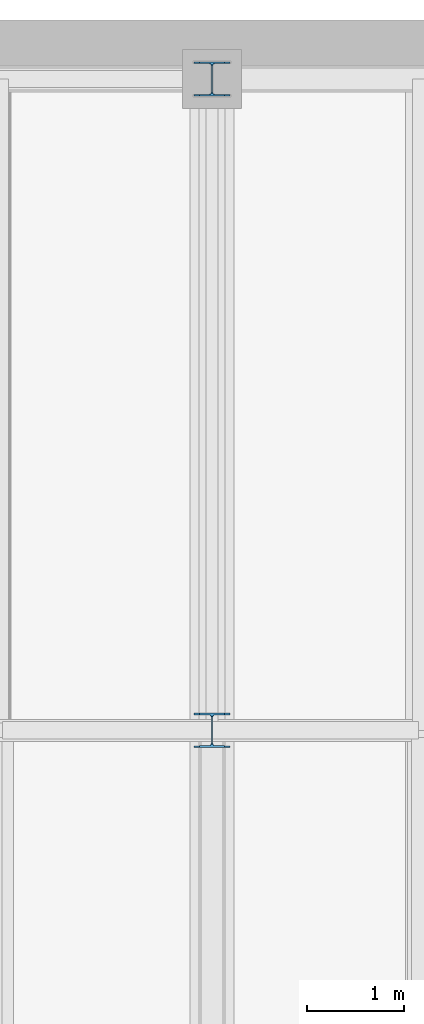
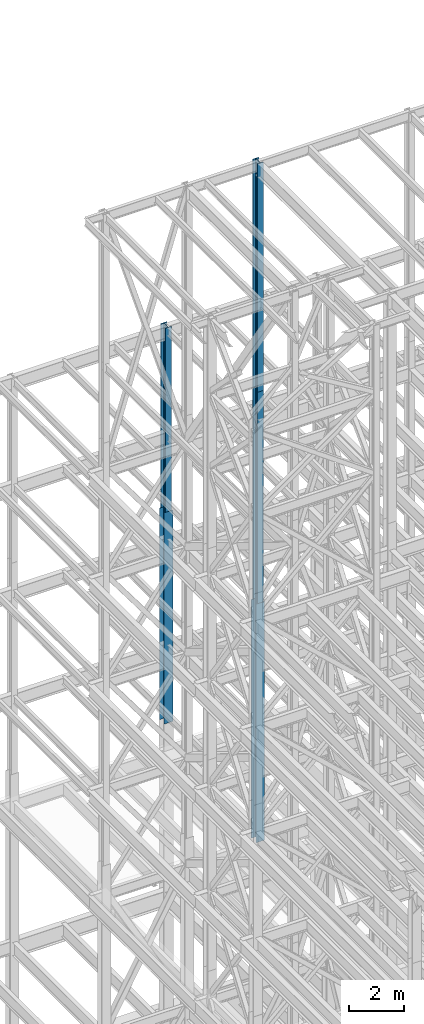
# One storey, part 56 of 150: 5 columns.
"""IFC2X3 building model written with IfcOpenShell, lengths in millimetres."""

from ifc_helpers import new_model, si_unit, frame, origin_with_axes, origin_2d_with_axis, place, context, subcontext, project, spatial, i_section, extrude, material, type_object, element, save


model = new_model("IFC2X3")

# Units and contexts
model_context = context("Model", 3, precision=1e-05, world=origin_with_axes())
body_context = subcontext(model_context, "Body", "Model", "MODEL_VIEW")
ifc_project = project(units=[si_unit("LENGTHUNIT", "METRE", prefix="MILLI"), si_unit("AREAUNIT", "SQUARE_METRE"), si_unit("VOLUMEUNIT", "CUBIC_METRE"), si_unit("MASSUNIT", "GRAM", prefix="KILO"), si_unit("TIMEUNIT", "SECOND"), si_unit("PLANEANGLEUNIT", "RADIAN"), si_unit("SOLIDANGLEUNIT", "STERADIAN"), si_unit("THERMODYNAMICTEMPERATUREUNIT", "DEGREE_CELSIUS"), si_unit("LUMINOUSINTENSITYUNIT", "LUMEN")], contexts=[model_context])

# Site, building, storey
site_placement = place(None, origin_with_axes())
site = spatial("IfcSite", under=ifc_project, at=site_placement, CompositionType="ELEMENT")
building_placement = place(site_placement, origin_with_axes())
building = spatial("IfcBuilding", under=site, at=building_placement, Name="Undefined", CompositionType="ELEMENT")
storey_placement = place(building_placement, origin_with_axes())
storey = spatial("IfcBuildingStorey", under=building, at=storey_placement, Name="Undefined", CompositionType="ELEMENT", Elevation=0.0)

# Columns
ifc_material = material(Name="STEEL/A992")
column_type_1 = type_object("IfcColumnType", Name="W14X61", PredefinedType="NOTDEFINED")
column_1_placement = place(storey_placement, frame((11785.6, 38862.0, 46253.4), z_axis=(0.0, 0.0, 1.0), x_axis=(1.0, 0.0, 0.0)))
element("IfcColumn", 1, at=column_1_placement, inside=storey, type_object=column_type_1, material=ifc_material, Name="COLUMN", ObjectType="W14X61", context=body_context, shape_type="SweptSolid", body=[
    extrude(i_section(OverallWidth=254.0, OverallDepth=352.425, WebThickness=9.5249, FlangeThickness=16.383, FilletRadius=21.717, at=origin_2d_with_axis()), frame((0.0, 0.0, 8229.60000000002), z_axis=(0.0, 0.0, -1.0), x_axis=(-1.0, 0.0, 0.0)), (0.0, 0.0, 1.0), 8229.60000000001),
])
column_type_2 = type_object("IfcColumnType", Name="W14X68", PredefinedType="NOTDEFINED")
column_2_placement = place(storey_placement, frame((11785.6, 32131.0, 55702.2), z_axis=(0.0, 0.0, 1.0), x_axis=(1.0, 0.0, 0.0)))
element("IfcColumn", 2, at=column_2_placement, inside=storey, type_object=column_type_2, material=ifc_material, Name="COLUMN", ObjectType="W14X68", context=body_context, shape_type="SweptSolid", body=[
    extrude(i_section(OverallWidth=254.0, OverallDepth=355.6, WebThickness=11.1125, FlangeThickness=18.288, FilletRadius=21.3994, at=origin_2d_with_axis()), frame((0.0, 0.0, 10210.8), z_axis=(0.0, 0.0, -1.0), x_axis=(-1.0, 0.0, 0.0)), (0.0, 0.0, 1.0), 10210.8),
])
column_3_placement = place(storey_placement, frame((11785.6, 32131.0, 46253.4009448801), z_axis=(0.0, 0.0, 1.0), x_axis=(1.0, 0.0, 0.0)))
element("IfcColumn", 3, at=column_3_placement, inside=storey, type_object=column_type_2, material=ifc_material, Name="COLUMN", ObjectType="W14X68", context=body_context, shape_type="SweptSolid", body=[
    extrude(i_section(OverallWidth=254.0, OverallDepth=355.6, WebThickness=11.1125, FlangeThickness=18.288, FilletRadius=21.3994, at=origin_2d_with_axis()), frame((0.0, 0.0, 9448.79905511992), z_axis=(0.0, 0.0, -1.0), x_axis=(-1.0, 0.0, 0.0)), (0.0, 0.0, 1.0), 9448.79905511991),
])
column_type_3 = type_object("IfcColumnType", Name="W14X90", PredefinedType="NOTDEFINED")
column_4_placement = place(storey_placement, frame((11785.6, 38862.0, 36804.6012877801), z_axis=(0.0, 0.0, 1.0), x_axis=(1.0, 0.0, 0.0)))
element("IfcColumn", 4, at=column_4_placement, inside=storey, type_object=column_type_3, material=ifc_material, Name="COLUMN", ObjectType="W14X90", context=body_context, shape_type="SweptSolid", body=[
    extrude(i_section(OverallWidth=368.3, OverallDepth=355.6, WebThickness=11.1125, FlangeThickness=18.034, FilletRadius=32.7659, at=origin_2d_with_axis()), frame((0.0, 0.0, 9448.79871221987), z_axis=(0.0, 0.0, -1.0), x_axis=(-1.0, 0.0, 0.0)), (0.0, 0.0, 1.0), 9448.79871221987),
])
column_5_placement = place(storey_placement, frame((11785.6, 32131.0, 35585.4), z_axis=(0.0, 0.0, 1.0), x_axis=(1.0, 0.0, 0.0)))
element("IfcColumn", 5, at=column_5_placement, inside=storey, type_object=column_type_3, material=ifc_material, Name="COLUMN", ObjectType="W14X90", context=body_context, shape_type="SweptSolid", body=[
    extrude(i_section(OverallWidth=368.3, OverallDepth=355.6, WebThickness=11.1125, FlangeThickness=18.034, FilletRadius=32.7659, at=origin_2d_with_axis()), frame((0.0, 0.0, 10668.0009448801), z_axis=(0.0, 0.0, -1.0), x_axis=(-1.0, 0.0, 0.0)), (0.0, 0.0, 1.0), 10668.0009448801),
])

save(model, "model.ifc")
